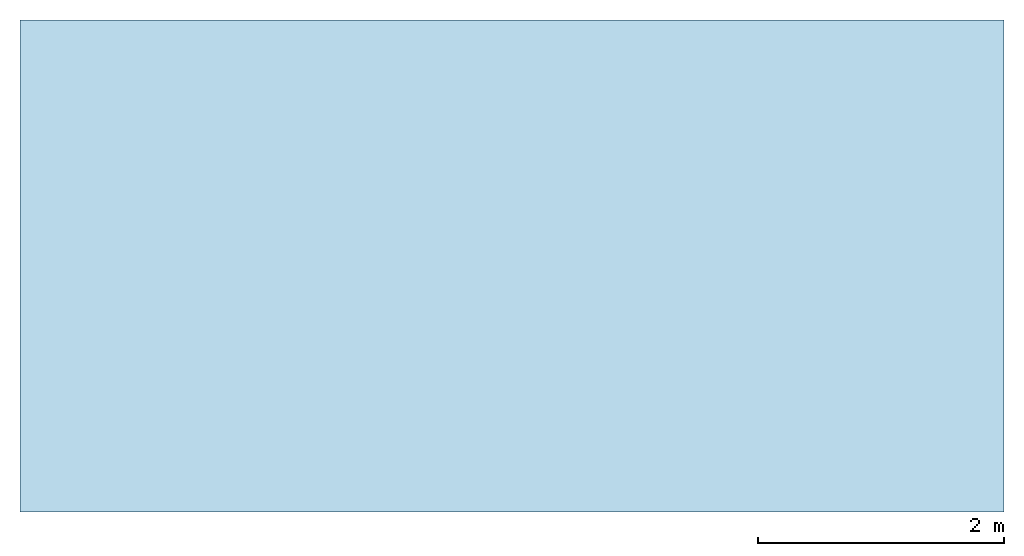
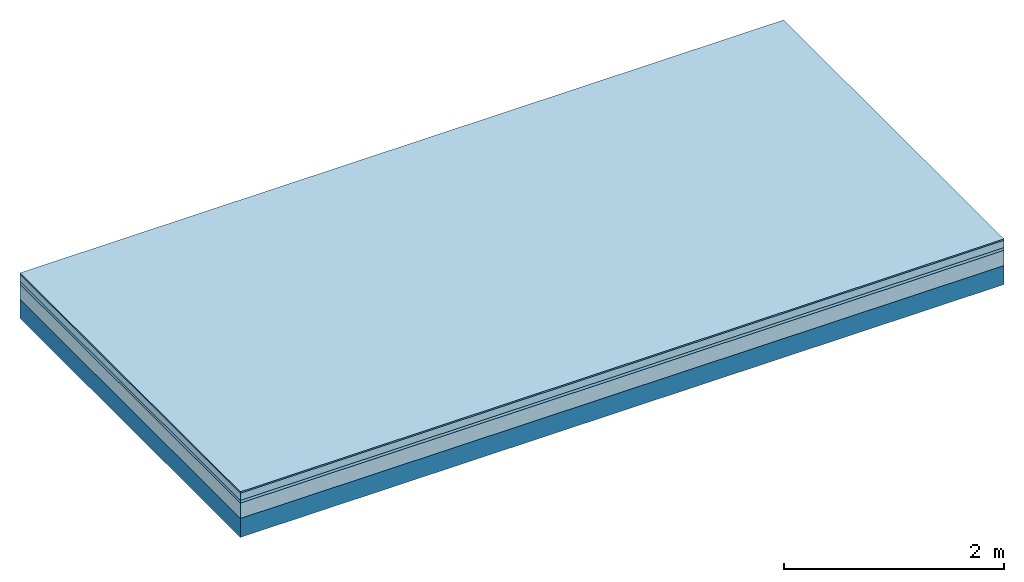
# One storey: 4 plates, 1 member, 1 element without a shape of its own.
"""IFC4 building model written with IfcOpenShell, lengths in metres."""

from ifc_helpers import new_model, si_unit, derived_unit, direction, frame, frame_2d, origin, origin_with_axes, place, context, project, spatial, rectangle, extrude, material, layer, layer_set, type_object, element, aggregate, save


model = new_model("IFC4")

# Units and contexts
plan_context = context("Plan", 3, precision=1e-05, world=origin(), true_north=direction((0.0, 1.0)))
model_context = context("Model", 3, precision=1e-05, world=origin(), true_north=direction((0.0, 1.0)))
ifc_project = project(units=[si_unit("LENGTHUNIT", "METRE"), derived_unit("SOUNDPRESSUREUNIT", [(si_unit("PRESSUREUNIT", "PASCAL", prefix="MICRO"), 0)]), si_unit("ENERGYUNIT", "JOULE", prefix="MEGA"), si_unit("MASSUNIT", "GRAM", prefix="KILO"), derived_unit("THERMALTRANSMITTANCEUNIT", [(si_unit("POWERUNIT", "WATT"), 1), (si_unit("AREAUNIT", "SQUARE_METRE"), -1), (si_unit("THERMODYNAMICTEMPERATUREUNIT", "KELVIN"), -1)]), derived_unit("AREADENSITYUNIT", [(si_unit("MASSUNIT", "GRAM", prefix="KILO"), 1), (si_unit("AREAUNIT", "SQUARE_METRE"), -1)]), derived_unit("USERDEFINED", [(si_unit("ENERGYUNIT", "JOULE", prefix="MEGA"), 1), (si_unit("AREAUNIT", "SQUARE_METRE"), -1)])], contexts=[plan_context, model_context])

# Site, building, storey
site = spatial("IfcSite", under=ifc_project)
building_placement = place(None, origin())
building = spatial("IfcBuilding", under=site, at=building_placement)
storey_placement = place(building_placement, origin())
storey = spatial("IfcBuildingStorey", under=building, at=storey_placement)

# Slab, member, plates
ifc_material_1 = material(Category="11.013")
ifc_layer_1 = layer(ifc_material_1, 0.015, Name="Flooring")
ifc_material_2 = material(Name="Cement screed", Category="04.006")
ifc_layer_2 = layer(ifc_material_2, 0.08, Name="On-material")
ifc_material_3 = material(Name="Wood fiber generic product", Category="10.009")
ifc_layer_3 = layer(ifc_material_3, 0.03, Name="Impact sound insulation")
ifc_material_4 = material(Category="01.002")
ifc_layer_4 = layer(ifc_material_4, 0.17, Name="Sub-floor")
ifc_material_5 = material(Name="Rigid, of the art")
ifc_layer_5 = layer(ifc_material_5, 0.0, Name="Bond")
ifc_layer_6 = layer(None, 0.21, Name="Supporting structure")
ifc_layer_set = layer_set([ifc_layer_1, ifc_layer_2, ifc_layer_3, ifc_layer_4, ifc_layer_5, ifc_layer_6])
slab_type = type_object("IfcSlabType", Name="A2196", PredefinedType="NOTDEFINED", material=ifc_layer_set)
slab_placement = place(None, frame((0.0, 0.0, 0.0), z_axis=(0.0, 0.0, -1.0), x_axis=(1.0, 0.0, 0.0)))
slab = element("IfcSlab", 1, at=slab_placement, inside=storey, type_object=slab_type, material=ifc_layer_set, Name="Slab #1")
ifc_material_6 = material(Name="Solid timber panel")
member_placement = place(slab_placement, origin())
member = element("IfcMember", 2, at=member_placement, material=ifc_material_6, Name="Supporting structure", context=plan_context, shape_type="SweptSolid", body=[
    extrude(rectangle(XDim=1.0, YDim=0.21, at=frame_2d((0.5, 0.105), x_axis=(1.0, 0.0))), frame((0.0, 4.0, 0.295), z_axis=(0.0, -1.0, 0.0), x_axis=(1.0, 0.0, 0.0)), (0.0, 0.0, 1.0), 4.0),
    extrude(rectangle(XDim=1.0, YDim=0.21, at=frame_2d((0.5, 0.105), x_axis=(1.0, 0.0))), frame((1.0, 4.0, 0.295), z_axis=(0.0, -1.0, 0.0), x_axis=(1.0, 0.0, 0.0)), (0.0, 0.0, 1.0), 4.0),
    extrude(rectangle(XDim=1.0, YDim=0.21, at=frame_2d((0.5, 0.105), x_axis=(1.0, 0.0))), frame((2.0, 4.0, 0.295), z_axis=(0.0, -1.0, 0.0), x_axis=(1.0, 0.0, 0.0)), (0.0, 0.0, 1.0), 4.0),
    extrude(rectangle(XDim=1.0, YDim=0.21, at=frame_2d((0.5, 0.105), x_axis=(1.0, 0.0))), frame((3.0, 4.0, 0.295), z_axis=(0.0, -1.0, 0.0), x_axis=(1.0, 0.0, 0.0)), (0.0, 0.0, 1.0), 4.0),
    extrude(rectangle(XDim=1.0, YDim=0.21, at=frame_2d((0.5, 0.105), x_axis=(1.0, 0.0))), frame((4.0, 4.0, 0.295), z_axis=(0.0, -1.0, 0.0), x_axis=(1.0, 0.0, 0.0)), (0.0, 0.0, 1.0), 4.0),
    extrude(rectangle(XDim=1.0, YDim=0.21, at=frame_2d((0.5, 0.105), x_axis=(1.0, 0.0))), frame((5.0, 4.0, 0.295), z_axis=(0.0, -1.0, 0.0), x_axis=(1.0, 0.0, 0.0)), (0.0, 0.0, 1.0), 4.0),
    extrude(rectangle(XDim=1.0, YDim=0.21, at=frame_2d((0.5, 0.105), x_axis=(1.0, 0.0))), frame((6.0, 4.0, 0.295), z_axis=(0.0, -1.0, 0.0), x_axis=(1.0, 0.0, 0.0)), (0.0, 0.0, 1.0), 4.0),
    extrude(rectangle(XDim=1.0, YDim=0.21, at=frame_2d((0.5, 0.105), x_axis=(1.0, 0.0))), frame((7.0, 4.0, 0.295), z_axis=(0.0, -1.0, 0.0), x_axis=(1.0, 0.0, 0.0)), (0.0, 0.0, 1.0), 4.0),
])
plate_1_placement = place(slab_placement, origin())
plate_1 = element("IfcPlate", 3, at=plate_1_placement, material=ifc_material_1, Name="Flooring", context=plan_context, shape_type="SweptSolid", body=[
    extrude(rectangle(XDim=8.0, YDim=4.0, at=frame_2d((4.0, 2.0), x_axis=(1.0, 0.0))), origin_with_axes(), (0.0, 0.0, 1.0), 0.015),
])
plate_2_placement = place(slab_placement, origin())
plate_2 = element("IfcPlate", 4, at=plate_2_placement, material=ifc_material_2, Name="On-material", context=plan_context, shape_type="SweptSolid", body=[
    extrude(rectangle(XDim=8.0, YDim=4.0, at=frame_2d((4.0, 2.0), x_axis=(1.0, 0.0))), frame((0.0, 0.0, 0.015), z_axis=(0.0, 0.0, 1.0), x_axis=(1.0, 0.0, 0.0)), (0.0, 0.0, 1.0), 0.08),
])
plate_3_placement = place(slab_placement, origin())
plate_3 = element("IfcPlate", 5, at=plate_3_placement, material=ifc_material_3, Name="Impact sound insulation", context=plan_context, shape_type="SweptSolid", body=[
    extrude(rectangle(XDim=8.0, YDim=4.0, at=frame_2d((4.0, 2.0), x_axis=(1.0, 0.0))), frame((0.0, 0.0, 0.095), z_axis=(0.0, 0.0, 1.0), x_axis=(1.0, 0.0, 0.0)), (0.0, 0.0, 1.0), 0.03),
])
plate_4_placement = place(slab_placement, origin())
plate_4 = element("IfcPlate", 6, at=plate_4_placement, material=ifc_material_4, Name="Sub-floor", context=plan_context, shape_type="SweptSolid", body=[
    extrude(rectangle(XDim=8.0, YDim=4.0, at=frame_2d((4.0, 2.0), x_axis=(1.0, 0.0))), frame((0.0, 0.0, 0.125), z_axis=(0.0, 0.0, 1.0), x_axis=(1.0, 0.0, 0.0)), (0.0, 0.0, 1.0), 0.17),
])
aggregate(slab, [plate_1, plate_2, plate_3, plate_4, member])

save(model, "model.ifc")
